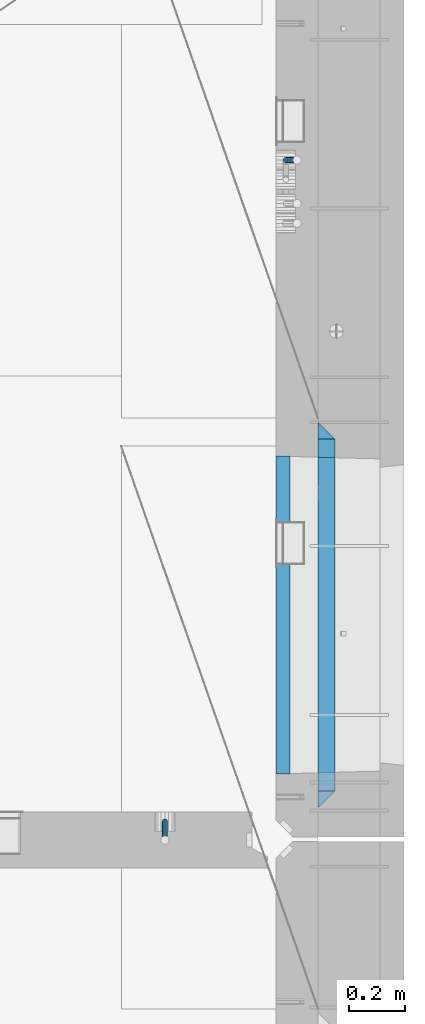
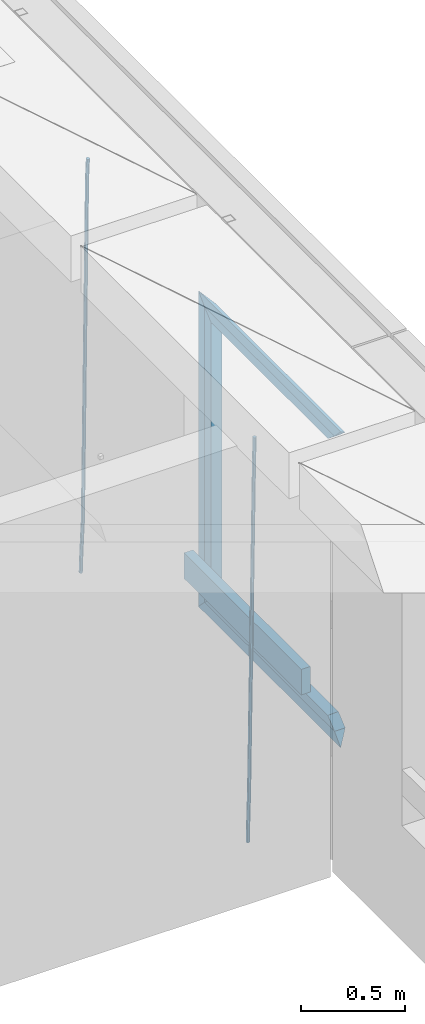
# One storey, part 128 of 341: 9 beams, 2 elements without a shape of their own.
"""IFC2X3 building model written with IfcOpenShell, lengths in millimetres."""

import ifcopenshell
import ifcopenshell.guid

model = None  # the IFC model being written
_history = None  # IfcOwnerHistory: only IFC2X3 demands one
_inside = {}  # id of a spatial element -> (the spatial element, [elements in it])
_under = {}  # id of a project, library or spatial element -> (it, [spatial elements below it])
_declared = {}  # id of a project -> (the project, [libraries it declares])
_typed = {}  # id of a type object -> (the type object, [elements of that type])
_made_of = {}  # id of a material, layer set ... -> (it, [elements and type objects made of it])


def new_model(schema):
    """Start an empty IFC model of exactly this schema.

    Asked for "IFC4X3", IfcOpenShell would pick the latest addendum, in which some entities
    have other attributes; the version numbers below select the first issue.
    IFC2X3 requires an IfcOwnerHistory on every rooted entity: one is made here for all.
    """
    global model, _history
    if schema == "IFC4X3":
        model = ifcopenshell.file(schema_version=(4, 3, 0, 0))
    else:
        model = ifcopenshell.file(schema=schema)
    _inside.clear()
    _under.clear()
    _declared.clear()
    _typed.clear()
    _made_of.clear()
    _history = None
    if model.schema == "IFC2X3":
        org = make("IfcOrganization", Name="unknown")
        user = make(
            "IfcPersonAndOrganization",
            ThePerson=make("IfcPerson", FamilyName="unknown"),
            TheOrganization=org,
        )
        app = make(
            "IfcApplication",
            ApplicationDeveloper=org,
            Version="unknown",
            ApplicationFullName="unknown",
            ApplicationIdentifier="unknown",
        )
        _history = make(
            "IfcOwnerHistory",
            OwningUser=user,
            OwningApplication=app,
            ChangeAction="ADDED",
            CreationDate=0,
        )
    return model


def make(cls, **values):
    """One entity of the class cls with the attributes given. An attribute that is None is left unset."""
    return model.create_entity(
        cls, **{name: value for name, value in values.items() if value is not None}
    )


def rooted(cls, **values):
    """An entity with a GlobalId (a new one), such as an element, a storey or a relation."""
    return make(cls, GlobalId=ifcopenshell.guid.new(), OwnerHistory=_history, **values)


def si_unit(unit_type, name, prefix=None):
    """IfcSIUnit, for example si_unit("LENGTHUNIT", "METRE", prefix="MILLI")."""
    return make("IfcSIUnit", UnitType=unit_type, Prefix=prefix, Name=name)


def assignment(units):
    """IfcUnitAssignment: the units of a project."""
    return None if units is None else make("IfcUnitAssignment", Units=units)


def point(xyz):
    """IfcCartesianPoint."""
    return None if xyz is None else make("IfcCartesianPoint", Coordinates=xyz)


def direction(xyz):
    """IfcDirection."""
    return None if xyz is None else make("IfcDirection", DirectionRatios=xyz)


def frame(location, z_axis=None, x_axis=None):
    """IfcAxis2Placement3D, a coordinate frame: its origin and axes. An axis left out is left unset."""
    return make(
        "IfcAxis2Placement3D",
        Location=point(location),
        Axis=direction(z_axis),
        RefDirection=direction(x_axis),
    )


def origin_with_axes():
    """The frame at (0, 0, 0) with the z axis (0, 0, 1) and the x axis (1, 0, 0) written out."""
    return frame((0.0, 0.0, 0.0), z_axis=(0.0, 0.0, 1.0), x_axis=(1.0, 0.0, 0.0))


def place(relative_to, where):
    """IfcLocalPlacement: puts the frame where relative to a parent placement (None: the world)."""
    return make(
        "IfcLocalPlacement", PlacementRelTo=relative_to, RelativePlacement=where
    )


def context(
    kind, dimensions, precision=None, world=None, true_north=None, identifier=None
):
    """IfcGeometricRepresentationContext, for example the 3D "Model" context."""
    return make(
        "IfcGeometricRepresentationContext",
        ContextIdentifier=identifier,
        ContextType=kind,
        CoordinateSpaceDimension=dimensions,
        Precision=precision,
        WorldCoordinateSystem=world,
        TrueNorth=true_north,
    )


def subcontext(parent, identifier, kind, view, scale=None):
    """IfcGeometricRepresentationSubContext, for example "Body" below "Model"."""
    return make(
        "IfcGeometricRepresentationSubContext",
        ContextIdentifier=identifier,
        ContextType=kind,
        ParentContext=parent,
        TargetScale=scale,
        TargetView=view,
    )


def project(units=None, contexts=None):
    """IfcProject with its units and contexts."""
    return rooted(
        "IfcProject",
        Name="project",
        RepresentationContexts=contexts,
        UnitsInContext=assignment(units),
    )


def spatial(cls, under=None, at=None, **own):
    """A site, building, storey or space (cls), placed at a placement, below another one or the project."""
    s = rooted(cls, ObjectPlacement=at, **own)
    if under is not None:
        _under.setdefault(under.id(), (under, []))[1].append(s)
    return s


def faces_of(points, faces, orient=None, outer=None):
    """IfcFace entities. A face is a list of loops; a loop is a list of indices into points, from 0.

    orient and outer hold one flag for each loop. By default every Orientation is true, the
    first loop of a face is its IfcFaceOuterBound and the others are IfcFaceBound.
    """
    made = []
    for i, loops in enumerate(faces):
        bounds = []
        for j, loop in enumerate(loops):
            is_outer = j == 0 if outer is None else outer[i][j]
            bounds.append(
                make(
                    "IfcFaceOuterBound" if is_outer else "IfcFaceBound",
                    Bound=make("IfcPolyLoop", Polygon=[points[k] for k in loop]),
                    Orientation=True if orient is None else orient[i][j],
                )
            )
        made.append(make("IfcFace", Bounds=bounds))
    return made


def faceted_brep(points, faces, orient=None, outer=None, voids=None):
    """IfcFacetedBrep: a solid bounded by flat faces; with voids (closed shells), ...WithVoids."""
    shared = [point(p) for p in points]
    hull = make("IfcClosedShell", CfsFaces=faces_of(shared, faces, orient, outer))
    if voids is None:
        return make("IfcFacetedBrep", Outer=hull)
    return make(
        "IfcFacetedBrepWithVoids",
        Outer=hull,
        Voids=[
            make(cls, CfsFaces=faces_of(shared, fs, o, b)) for cls, fs, o, b in voids
        ],
    )


def shape(context_of_items, identifier, shape_type, items):
    """IfcShapeRepresentation: the items that make up one representation, for example the "Body"."""
    return make(
        "IfcShapeRepresentation",
        ContextOfItems=context_of_items,
        RepresentationIdentifier=identifier,
        RepresentationType=shape_type,
        Items=items,
    )


def material(Name=None, Category=None):
    """IfcMaterial."""
    return make("IfcMaterial", Name=Name, Category=Category)


def made_of(thing, what):
    """Note that an element or type object is made of a material, layer set ...; save() writes the relation."""
    if what is not None:
        _made_of.setdefault(what.id(), (what, []))[1].append(thing)
    return thing


def type_object(cls, material=None, **own):
    """A type object (cls), such as IfcWallType, which elements share."""
    return made_of(rooted(cls, **own), material)


def element(
    cls,
    number,
    at=None,
    inside=None,
    cuts=None,
    type_object=None,
    material=None,
    context=None,
    identifier="Body",
    shape_type=None,
    held_by="IfcProductDefinitionShape",
    body=None,
    shapes=None,
    **own,
):
    """One element of the class cls, such as IfcWall. Its Tag is "e" and its number.

    at: its placement. inside: the storey or other place that contains it. cuts: it is an
    opening in that element (IfcRelVoidsElement). A single representation is given by context,
    identifier, shape_type and body (its items); several are given by shapes. held_by: the class
    of the entity that holds the representations. save() writes the other relations.
    """
    e = rooted(cls, Tag="e%d" % number, ObjectPlacement=at, **own)
    if body is not None:
        shapes = [shape(context, identifier, shape_type, body)]
    if shapes is not None:
        e.Representation = make(held_by, Representations=shapes)
    if inside is not None:
        _inside.setdefault(inside.id(), (inside, []))[1].append(e)
    if cuts is not None:
        rooted(
            "IfcRelVoidsElement", RelatingBuildingElement=cuts, RelatedOpeningElement=e
        )
    if type_object is not None:
        _typed.setdefault(type_object.id(), (type_object, []))[1].append(e)
    return made_of(e, material)


def aggregate(whole, parts):
    """IfcRelAggregates: a whole, such as a stair, and the parts it consists of."""
    return rooted("IfcRelAggregates", RelatingObject=whole, RelatedObjects=parts)


def save(model, path):
    """Write the relations noted so far, then the file.

    IfcRelAggregates (storeys below a building ...), IfcRelContainedInSpatialStructure (elements
    in a storey), IfcRelDefinesByType, IfcRelAssociatesMaterial and IfcRelDeclares: one each for
    every whole, place, type object, material and project.
    """
    for whole, parts in _under.values():
        aggregate(whole, parts)
    for where, things in _inside.values():
        rooted(
            "IfcRelContainedInSpatialStructure",
            RelatedElements=things,
            RelatingStructure=where,
        )
    for kind, things in _typed.values():
        rooted("IfcRelDefinesByType", RelatedObjects=things, RelatingType=kind)
    for what, things in _made_of.values():
        rooted("IfcRelAssociatesMaterial", RelatedObjects=things, RelatingMaterial=what)
    for by, libraries in _declared.values():
        rooted("IfcRelDeclares", RelatingContext=by, RelatedDefinitions=libraries)
    model.write(path)


model = new_model("IFC2X3")

# Units and contexts
model_context = context("Model", 3, precision=1e-05, world=origin_with_axes())
body_context = subcontext(model_context, "Body", "Model", "MODEL_VIEW")
ifc_project = project(units=[si_unit("LENGTHUNIT", "METRE", prefix="MILLI"), si_unit("AREAUNIT", "SQUARE_METRE"), si_unit("VOLUMEUNIT", "CUBIC_METRE"), si_unit("MASSUNIT", "GRAM", prefix="KILO"), si_unit("TIMEUNIT", "SECOND"), si_unit("PLANEANGLEUNIT", "RADIAN"), si_unit("SOLIDANGLEUNIT", "STERADIAN"), si_unit("THERMODYNAMICTEMPERATUREUNIT", "DEGREE_CELSIUS"), si_unit("LUMINOUSINTENSITYUNIT", "LUMEN")], contexts=[model_context])

# Site, building, storey
site_placement = place(None, origin_with_axes())
site = spatial("IfcSite", under=ifc_project, at=site_placement, CompositionType="ELEMENT")
building_placement = place(site_placement, origin_with_axes())
building = spatial("IfcBuilding", under=site, at=building_placement, CompositionType="ELEMENT")
storey_placement = place(building_placement, origin_with_axes())
storey = spatial("IfcBuildingStorey", under=building, at=storey_placement, Name="5", CompositionType="ELEMENT", Elevation=0.0)

# Assembly, beam
assembly_1_placement = place(storey_placement, origin_with_axes())
assembly_1 = element("IfcElementAssembly", 1, at=assembly_1_placement, inside=storey, AssemblyPlace="NOTDEFINED", PredefinedType="REINFORCEMENT_UNIT")
ifc_material_1 = material()
beam_type_1 = type_object("IfcBeamType", Name="D20", PredefinedType="NOTDEFINED")
beam_1_placement = place(assembly_1_placement, frame((34514.9999999961, 17044.9997581385, 93990.0), z_axis=(0.00020576299992186, -0.999642804629538, -0.0267249099901004), x_axis=(-4.30000201928125e-08, -0.0267249099948059, 0.999642825806181)))
beam_1 = element("IfcBeam", 2, at=beam_1_placement, type_object=beam_type_1, material=ifc_material_1, Name="JM20", ObjectType="D20", context=body_context, shape_type="Brep", body=[
    faceted_brep([(0.0, -10.0, 0.0), (-4.19531716033816e-08, -7.07106781186667, -7.07106781187031), (60.4266690400545, -7.0710677960451, -7.07106780570757), (60.4266690441291, -9.99999998418934, 6.15546014159918e-09), (0.0, 0.0, -10.0), (60.426669036824, 1.58106558956206e-08, -9.99999999384454), (4.196772351861e-08, 7.07106781186303, -7.07106781186667), (60.4266690363438, 7.07106782768096, -7.07106780570757), (0.0, 10.0, 0.0), (60.4266690388904, 10.0000000158179, 6.15182216279209e-09), (4.196772351861e-08, 7.07106781185939, 7.07106781185939), (60.4266690429649, 7.07106782768096, 7.07106781802577), (0.0, 0.0, 10.0), (60.4266690461809, 1.58179318532348e-08, 10.0000000061555), (-4.19531716033816e-08, -7.07106781187031, 7.07106781185939), (60.4266690466611, -7.07106779605238, 7.07106781802213), (61.0378400410118, -7.07106779588503, -7.07106780564936), (60.991799419251, -9.99999998403655, 6.21366780251265e-09), (61.0569027789461, 1.5985278878361e-08, -9.99999999378269), (61.0378209396877, 7.07106782784831, -7.07106780564936), (60.9917724058905, 10.0000000159635, 6.21366780251265e-09), (60.9457317841297, 7.07106782781193, 7.0710678180767), (60.9266690461809, 1.59488990902901e-08, 10.0000000062028), (60.9457508854539, -7.07106779591413, 7.0710678180767), (61.6489592143771, -7.07106614513759, -7.06310863441468), (61.5568818710308, -9.9999984576425, 0.00735959856683621), (61.6870830769039, 1.71821739058942e-06, -9.99179257185824), (61.6489210170112, 7.07106947854481, -7.06310888312146), (61.556827851804, 10.0000015422847, 0.00735924683976918), (61.4647505084577, 7.07106922979438, 7.07782747982128), (61.4266266459163, 1.36643211590126e-06, 10.0065114172685), (61.464788705809, -7.07106639389531, 7.07782772852806), (176.543135720174, -7.07075579406956, -5.56673531796696), (176.451058376813, -9.99968810657447, 1.50373291501455), (176.581259582701, 0.000312069292704109, -8.49541925541052), (176.543097522794, 7.07137982961285, -5.56673556667374), (176.451004357587, 10.00031189336, 1.50373256329476), (176.35892701424, 7.07137958085514, 8.57420079627263), (176.320803151699, 0.000311717507429421, 11.5028847337162), (176.358965211621, -7.07075604281999, 8.57420104497578), (177.098753836006, -7.07075429323595, -5.55949898843028), (176.98362511232, -9.99968666800123, 1.510669025065), (177.146421932586, 0.000313595905026887, -8.48805862247536), (177.098706077581, 7.07138133041735, -5.55949936166144), (176.983557571715, 10.0003133318824, 1.51066849724157), (176.868428848029, 7.07138095712435, 8.58083651073321), (176.820760751449, 0.000313067976094317, 11.5093961447819), (176.868476606425, -7.07075466652896, 8.58083688396073), (177.654312950661, -7.07075204110879, -5.54863964998367), (177.516135294456, -9.99968450931192, 1.52107783331303), (177.711524267797, 0.000315886711177882, -8.47701274570863), (177.654255632195, 7.07138358250813, -5.54864021007961), (177.516054233929, 10.0003154905207, 1.5210770412159), (177.377876577739, 7.0713830223176, 8.59079452451624), (177.320665260588, 0.000315094497636892, 11.5191676202448), (177.377933896176, -7.07075260129932, 8.59079508461218), (299.499456785634, -7.07025810522464, -3.16697112782276), (299.361279129444, -9.99919057342777, 3.90274635547394), (299.556668102785, 0.000809822595329024, -6.09534422354773), (299.499399467197, 7.07187751838501, -3.1669716879187), (299.361198068917, 10.0008094264049, 3.90274556338045), (299.223020412712, 7.07187695819448, 10.9724630466735), (299.165809095575, 0.000809030381788034, 13.9008361423985), (299.223077731163, -7.07025866542244, 10.9724636067695), (300.03174732349, -7.07025594743027, -3.15656661289177), (299.971788958996, -9.99918809853989, 3.91467979818117), (300.056572611924, 0.000811849109595641, -6.08557274808481), (300.031722507032, 7.07187967631762, -3.15656653768019), (299.971753863239, 10.0008119014747, 3.91467990454839), (299.91179549876, 7.07187975035777, 10.9859263156177), (299.886970210311, 0.000811953817901667, 13.9149324508144), (299.911820315203, -7.0702558733974, 10.9859262404061), (300.564137759997, -7.07025623699155, -3.15794273276697), (300.582413367199, -9.99918843065097, 3.91310145956595), (300.556570941641, 0.000811577163403854, -6.0868651410201), (300.564145451674, 7.07187938674906, -3.15794274158179), (300.582424244858, 10.0008115693345, 3.91310144710224), (300.600699852032, 7.07187937566778, 10.9841456394352), (300.608266670402, 0.000811561512819026, 13.9130680476919), (300.600692160384, -7.07025624805829, 10.98414564825), (2294.16589219622, -7.0713405251372, -8.31099358700158), (2294.1841678034, -10.0002727187966, -1.23994939466866), (2294.15832537785, -0.000272710982244462, -11.2399159952547), (2294.16589988787, 7.07079509858886, -8.31099359582004), (2294.18417868105, 9.99972728118883, -1.23994940713601), (2294.20245428824, 7.07079508752213, 5.83109478519327), (2294.2100211066, -0.00027272663282929, 8.76001719345368), (2294.20244659658, -7.07134053620393, 5.83109479401173), (2294.7782683276, -7.07134085819416, -8.31257645345977), (2294.72126025338, -10.000273010919, -1.24133766827799), (2294.84007459224, -0.000273081772320438, -11.2416781768807), (2294.87047377572, 7.07079471537872, -8.31281477453012), (2294.85165844864, 9.9997269181622, -1.24167470516841), (2294.7946503744, 7.07079476544459, 5.82956408001337), (2294.73284410976, -0.000273010977252852, 8.75866580342336), (2294.7024449263, -7.07134080815013, 5.82980240107645), (2295.39054023061, -7.0793250091956, -8.30442771922026), (2295.25826128852, -10.0072756143927, -1.23419071494573), (2295.52170777075, -0.00916171800054144, -11.2326063125765), (2295.57492774284, 7.06160849139269, -8.30343918807193), (2295.51902460904, 9.99102432676591, -1.23279272078435), (2295.38674566693, 7.06307372157607, 5.83744428349019), (2295.25557812679, -0.0070895696117077, 8.76562287684646), (2295.20235815471, -7.07785977901949, 5.83645575234186), (2317.1947101649, -7.36365585014573, -8.01423575520312), (2317.06243122277, -10.2916064553428, -0.94399875092131), (2317.32587770502, -0.293492558957951, -10.9424143485521), (2317.37909767711, 6.77727765044983, -8.01324722405116), (2317.32319454331, 9.70669348581578, -0.942600756767206), (2317.1909156012, 6.77874288063322, 6.12763624751096), (2317.05974806109, -0.291420410569117, 9.0558148408636), (2317.00652808898, -7.36219061996962, 6.12664771636264), (2317.83015404257, -7.37194216843636, -8.00577862486898), (2317.72252095213, -10.300214160583, -0.935213608652703), (2317.90419832576, -0.301033978277701, -10.9347174723516), (2317.90127966482, 6.77046829039318, -8.00629749759901), (2317.82310777172, 9.70017451494641, -0.935947405505431), (2317.71547468127, 6.77190252279979, 6.13461761071085), (2317.64143039809, -0.29900566735887, 9.06355645819713), (2317.64434905903, -7.37050793602975, 6.13513648344451), (2318.46565174212, -7.3700661537805, -7.99751648408346), (2318.38266643914, -10.2982456018653, -0.926623872735945), (2318.48256818345, -0.299336209594912, -10.9272153854981), (2318.42350634121, 6.77200652527245, -7.99954269419686), (2318.32306384158, 9.70166538090416, -0.929489366557391), (2318.2400785386, 6.77348593281204, 6.14140324480104), (2318.22316209726, -0.297244011366274, 9.07110214621207), (2318.2822239395, -7.36858674623363, 6.1434294549108), (2418.48643733139, -7.07180401323421, -6.70013846199799), (2418.4034520284, -9.99998346132634, 0.370754149349523), (2418.5033537727, -0.00107406904135132, -9.62983736341266), (2418.44429193046, 7.07026866581873, -6.70216467211139), (2418.34384943081, 9.99992752145772, 0.367888655531715), (2418.26086412782, 7.0717480733656, 7.43878126688651), (2418.24394768651, 0.00101812917273492, 10.3684801682975), (2418.30300952874, -7.07032460568735, 7.44080747699627)], [[[0, 1, 2, 3]], [[1, 4, 5, 2]], [[4, 6, 7, 5]], [[6, 8, 9, 7]], [[8, 10, 11, 9]], [[10, 12, 13, 11]], [[12, 14, 15, 13]], [[14, 0, 3, 15]], [[14, 12, 10, 8, 6, 4, 1, 0]], [[3, 2, 16, 17]], [[2, 5, 18, 16]], [[5, 7, 19, 18]], [[7, 9, 20, 19]], [[9, 11, 21, 20]], [[11, 13, 22, 21]], [[13, 15, 23, 22]], [[15, 3, 17, 23]], [[17, 16, 24, 25]], [[16, 18, 26, 24]], [[18, 19, 27, 26]], [[19, 20, 28, 27]], [[20, 21, 29, 28]], [[21, 22, 30, 29]], [[22, 23, 31, 30]], [[23, 17, 25, 31]], [[25, 24, 32, 33]], [[24, 26, 34, 32]], [[26, 27, 35, 34]], [[27, 28, 36, 35]], [[28, 29, 37, 36]], [[29, 30, 38, 37]], [[30, 31, 39, 38]], [[31, 25, 33, 39]], [[33, 32, 40, 41]], [[32, 34, 42, 40]], [[34, 35, 43, 42]], [[35, 36, 44, 43]], [[36, 37, 45, 44]], [[37, 38, 46, 45]], [[38, 39, 47, 46]], [[39, 33, 41, 47]], [[41, 40, 48, 49]], [[40, 42, 50, 48]], [[42, 43, 51, 50]], [[43, 44, 52, 51]], [[44, 45, 53, 52]], [[45, 46, 54, 53]], [[46, 47, 55, 54]], [[47, 41, 49, 55]], [[49, 48, 56, 57]], [[48, 50, 58, 56]], [[50, 51, 59, 58]], [[51, 52, 60, 59]], [[52, 53, 61, 60]], [[53, 54, 62, 61]], [[54, 55, 63, 62]], [[55, 49, 57, 63]], [[57, 56, 64, 65]], [[56, 58, 66, 64]], [[58, 59, 67, 66]], [[59, 60, 68, 67]], [[60, 61, 69, 68]], [[61, 62, 70, 69]], [[62, 63, 71, 70]], [[63, 57, 65, 71]], [[65, 64, 72, 73]], [[64, 66, 74, 72]], [[66, 67, 75, 74]], [[67, 68, 76, 75]], [[68, 69, 77, 76]], [[69, 70, 78, 77]], [[70, 71, 79, 78]], [[71, 65, 73, 79]], [[73, 72, 80, 81]], [[72, 74, 82, 80]], [[74, 75, 83, 82]], [[75, 76, 84, 83]], [[76, 77, 85, 84]], [[77, 78, 86, 85]], [[78, 79, 87, 86]], [[79, 73, 81, 87]], [[81, 80, 88, 89]], [[80, 82, 90, 88]], [[82, 83, 91, 90]], [[83, 84, 92, 91]], [[84, 85, 93, 92]], [[85, 86, 94, 93]], [[86, 87, 95, 94]], [[87, 81, 89, 95]], [[89, 88, 96, 97]], [[88, 90, 98, 96]], [[90, 91, 99, 98]], [[91, 92, 100, 99]], [[92, 93, 101, 100]], [[93, 94, 102, 101]], [[94, 95, 103, 102]], [[95, 89, 97, 103]], [[97, 96, 104, 105]], [[96, 98, 106, 104]], [[98, 99, 107, 106]], [[99, 100, 108, 107]], [[100, 101, 109, 108]], [[101, 102, 110, 109]], [[102, 103, 111, 110]], [[103, 97, 105, 111]], [[105, 104, 112, 113]], [[104, 106, 114, 112]], [[106, 107, 115, 114]], [[107, 108, 116, 115]], [[108, 109, 117, 116]], [[109, 110, 118, 117]], [[110, 111, 119, 118]], [[111, 105, 113, 119]], [[113, 112, 120, 121]], [[112, 114, 122, 120]], [[114, 115, 123, 122]], [[115, 116, 124, 123]], [[116, 117, 125, 124]], [[117, 118, 126, 125]], [[118, 119, 127, 126]], [[119, 113, 121, 127]], [[121, 120, 128, 129]], [[120, 122, 130, 128]], [[122, 123, 131, 130]], [[123, 124, 132, 131]], [[124, 125, 133, 132]], [[125, 126, 134, 133]], [[126, 127, 135, 134]], [[127, 121, 129, 135]], [[130, 131, 132, 133, 134, 135, 129, 128]]]),
])
aggregate(assembly_1, [beam_1])

# Assembly, beams
assembly_2_placement = place(storey_placement, origin_with_axes())
assembly_2 = element("IfcElementAssembly", 3, at=assembly_2_placement, inside=storey, AssemblyPlace="NOTDEFINED", PredefinedType="REINFORCEMENT_UNIT")
beam_2_placement = place(assembly_2_placement, frame((34944.9999977209, 19397.5002651175, 93995.0), z_axis=(0.999642804629538, 0.000205762999925497, -0.0267249099901003), x_axis=(0.0267249109941254, -4.30000210532798e-08, 0.999642825779465)))
beam_2 = element("IfcBeam", 4, at=beam_2_placement, type_object=beam_type_1, material=ifc_material_1, Name="JM20", ObjectType="D20", context=body_context, shape_type="Brep", body=[
    faceted_brep([(0.0, -10.0, 0.0), (-4.19531716033816e-08, -7.07106781186667, -7.07106781187031), (60.4266690400545, -7.0710677960451, -7.07106780570757), (60.4266690441291, -9.99999998418934, 6.15546014159918e-09), (0.0, 0.0, -10.0), (60.426669036824, 1.58106558956206e-08, -9.99999999384454), (4.196772351861e-08, 7.07106781186303, -7.07106781186667), (60.4266690363438, 7.07106782768096, -7.07106780570757), (0.0, 10.0, 0.0), (60.4266690388904, 10.0000000158179, 6.15182216279209e-09), (4.196772351861e-08, 7.07106781185939, 7.07106781185939), (60.4266690429649, 7.07106782768096, 7.07106781802577), (0.0, 0.0, 10.0), (60.4266690461809, 1.58179318532348e-08, 10.0000000061555), (-4.19531716033816e-08, -7.07106781187031, 7.07106781185939), (60.4266690466611, -7.07106779605238, 7.07106781802213), (61.0378400410118, -7.07106779588503, -7.07106780564936), (60.991799419251, -9.99999998403655, 6.21366780251265e-09), (61.0569027789461, 1.5985278878361e-08, -9.99999999378269), (61.0378209396877, 7.07106782784831, -7.07106780564936), (60.9917724058905, 10.0000000159635, 6.21366780251265e-09), (60.9457317841297, 7.07106782781193, 7.0710678180767), (60.9266690461809, 1.59488990902901e-08, 10.0000000062028), (60.9457508854539, -7.07106779591413, 7.0710678180767), (61.6489592143771, -7.07106614513759, -7.06310863441468), (61.5568818710308, -9.9999984576425, 0.00735959856683621), (61.6870830769039, 1.71821739058942e-06, -9.99179257185824), (61.6489210170112, 7.07106947854481, -7.06310888312146), (61.556827851804, 10.0000015422847, 0.00735924683976918), (61.4647505084577, 7.07106922979438, 7.07782747982128), (61.4266266459163, 1.36643211590126e-06, 10.0065114172685), (61.464788705809, -7.07106639389531, 7.07782772852806), (176.543135720174, -7.07075579406956, -5.56673531796696), (176.451058376813, -9.99968810657447, 1.50373291501455), (176.581259582701, 0.000312069292704109, -8.49541925541052), (176.543097522794, 7.07137982961285, -5.56673556667374), (176.451004357587, 10.00031189336, 1.50373256329476), (176.35892701424, 7.07137958085514, 8.57420079627263), (176.320803151699, 0.000311717507429421, 11.5028847337162), (176.358965211621, -7.07075604281999, 8.57420104497578), (177.098753836006, -7.07075429323595, -5.55949898843028), (176.98362511232, -9.99968666800123, 1.510669025065), (177.146421932586, 0.000313595905026887, -8.48805862247536), (177.098706077581, 7.07138133041735, -5.55949936166144), (176.983557571715, 10.0003133318824, 1.51066849724157), (176.868428848029, 7.07138095712435, 8.58083651073321), (176.820760751449, 0.000313067976094317, 11.5093961447819), (176.868476606425, -7.07075466652896, 8.58083688396073), (177.654312950661, -7.07075204110879, -5.54863964998367), (177.516135294456, -9.99968450931192, 1.52107783331303), (177.711524267797, 0.000315886711177882, -8.47701274570863), (177.654255632195, 7.07138358250813, -5.54864021007961), (177.516054233929, 10.0003154905207, 1.5210770412159), (177.377876577739, 7.0713830223176, 8.59079452451624), (177.320665260588, 0.000315094497636892, 11.5191676202448), (177.377933896176, -7.07075260129932, 8.59079508461218), (299.436796249574, -7.07025836271714, -3.1681962331204), (299.298618593355, -9.99919083092027, 3.90152125031091), (299.494007566798, 0.000809565110102994, -6.09656932889993), (299.436738931283, 7.07187726089978, -3.16819679320906), (299.298537533061, 10.0008091689197, 3.90152045822106), (299.160359876842, 7.07187670072017, 10.9712379416487), (299.103148559603, 0.000808772889286047, 13.8996110374392), (299.160417195119, -7.07025892290039, 10.9712385017483), (299.98743051647, -7.07025613056248, -3.15743315966392), (299.971788958996, -9.99918809853989, 3.91467979818117), (299.993912075952, 0.000811591617093654, -6.08679785393178), (299.987423933868, 7.07187949325817, -3.1574327280432), (299.971753863239, 10.0008119014747, 3.91467990454839), (299.95611230444, 7.07187992653053, 10.9867922621015), (299.949630744944, 0.000812204350950196, 13.9161569563694), (299.956118887014, -7.07025569729012, 10.9867918304735), (300.538107039494, -7.07025785017686, -3.16575821840888), (300.644985195438, -9.99919020432935, 3.90450175465594), (300.493854948218, 0.000810030429420294, -6.09435592770024), (300.538151196495, 7.071877773491, -3.16575855385963), (300.645047642858, 10.0008097955724, 3.90450128024895), (300.751925798773, 7.07187744142357, 10.9747612533101), (300.796177890064, 0.000809560813650023, 13.9033589625978), (300.751881641787, -7.07025818224065, 10.9747615887682), (2293.36490490142, -7.07648090940347, -33.2930642912361), (2293.47178305736, -10.0054132635523, -26.2228043181785), (2293.32065281013, -0.00541302880083094, -36.2216620005347), (2293.36494905842, 7.06565471425711, -33.2930646266868), (2293.47184550477, 9.99458673634581, -26.2228047925819), (2293.57872366071, 7.06565438219332, -19.1525448195243), (2293.62297575199, -0.00541349841296324, -16.2239471102366), (2293.57867950371, -7.0764812414709, -19.1525444840736), (2294.0658245362, -7.07648309818615, -33.3036607065333), (2294.05312277409, -10.0054150789219, -26.2315929392535), (2294.10928714235, -0.00541549149056664, -36.2335844756526), (2294.15805078732, 7.06565223761572, -33.3050546393533), (2294.18355038921, 9.99458451388637, -26.2335642579346), (2294.17084862708, 7.06565253314329, -19.1614964906439), (2294.12738602093, -0.00541507354500936, -16.2315727215355), (2294.07862237596, -7.07648280265857, -19.1601025578348), (2294.76670261032, -7.08562269121467, -33.294332712383), (2294.63442802057, -10.0129954178956, -26.2238563411993), (2294.89787471293, -0.0156988342423574, -36.2230891548279), (2294.95110548967, 7.05531064255774, -33.2944998654275), (2294.89521307347, 9.98530428734011, -26.2240927312887), (2294.76293848372, 7.0579315606592, -19.1536163601049), (2294.63176638114, -0.0119922963167483, -16.2248599176673), (2294.57853560438, -7.08300177311321, -19.1534492070678), (2316.52657204497, -7.36937582653991, -33.0047303660212), (2316.39429745522, -10.2967485532172, -25.9342539948302), (2316.65774414754, -0.299451969567599, -35.9334868084661), (2316.7109749243, 6.7715575072325, -33.0048975190657), (2316.65508250811, 9.70155115201487, -25.9344903849269), (2316.52280791836, 6.7741784253376, -18.8640140137468), (2316.39163581574, -0.295745431634714, -15.9352575713092), (2316.33840503903, -7.36675490843481, -18.863846860706), (2317.16202064224, -7.37766220584308, -32.9962731735213), (2317.05438744847, -10.3053562613532, -25.9254688497131), (2317.23607125619, -0.306993473008333, -35.925789846493), (2317.23316144495, 6.76474808850253, -32.9979477328052), (2317.15499573652, 9.6950321815566, -25.9278370341635), (2317.04736254275, 6.7673381260538, -18.8570327103698), (2316.97331192881, -0.303330606784584, -15.9275160373909), (2316.97622174003, -7.37507216829545, -18.8553581510787), (2317.79752306276, -7.37578610372293, -32.9880110666527), (2317.71453320107, -10.3033876998124, -25.9168792378296), (2317.81444760226, -0.305295583297266, -35.918287695793), (2317.75539265381, 6.76628640723357, -32.9911928173897), (2317.65495180529, 9.69652304524061, -25.9213789128698), (2317.5719619436, 6.76892144914746, -18.8502470840467), (2317.55503740412, -0.301569071270933, -15.9199704549137), (2317.61409235255, -7.3731510618054, -18.847065333317), (2417.8183084176, -7.07752398473531, -31.6906369377139), (2417.73531855589, -10.0051255808248, -24.6195051088798), (2417.83523295709, -0.007033464313281, -34.6209135668432), (2417.77617800863, 7.06454852621755, -31.6938186884508), (2417.67573716014, 9.99478516423187, -24.6240047839383), (2417.59274729842, 7.06718356813872, -17.5528729551006), (2417.57582275895, -0.00330695228694822, -14.6225963259749), (2417.6348777074, -7.07488894281778, -17.5496912043673)], [[[0, 1, 2, 3]], [[1, 4, 5, 2]], [[4, 6, 7, 5]], [[6, 8, 9, 7]], [[8, 10, 11, 9]], [[10, 12, 13, 11]], [[12, 14, 15, 13]], [[14, 0, 3, 15]], [[14, 12, 10, 8, 6, 4, 1, 0]], [[3, 2, 16, 17]], [[2, 5, 18, 16]], [[5, 7, 19, 18]], [[7, 9, 20, 19]], [[9, 11, 21, 20]], [[11, 13, 22, 21]], [[13, 15, 23, 22]], [[15, 3, 17, 23]], [[17, 16, 24, 25]], [[16, 18, 26, 24]], [[18, 19, 27, 26]], [[19, 20, 28, 27]], [[20, 21, 29, 28]], [[21, 22, 30, 29]], [[22, 23, 31, 30]], [[23, 17, 25, 31]], [[25, 24, 32, 33]], [[24, 26, 34, 32]], [[26, 27, 35, 34]], [[27, 28, 36, 35]], [[28, 29, 37, 36]], [[29, 30, 38, 37]], [[30, 31, 39, 38]], [[31, 25, 33, 39]], [[33, 32, 40, 41]], [[32, 34, 42, 40]], [[34, 35, 43, 42]], [[35, 36, 44, 43]], [[36, 37, 45, 44]], [[37, 38, 46, 45]], [[38, 39, 47, 46]], [[39, 33, 41, 47]], [[41, 40, 48, 49]], [[40, 42, 50, 48]], [[42, 43, 51, 50]], [[43, 44, 52, 51]], [[44, 45, 53, 52]], [[45, 46, 54, 53]], [[46, 47, 55, 54]], [[47, 41, 49, 55]], [[49, 48, 56, 57]], [[48, 50, 58, 56]], [[50, 51, 59, 58]], [[51, 52, 60, 59]], [[52, 53, 61, 60]], [[53, 54, 62, 61]], [[54, 55, 63, 62]], [[55, 49, 57, 63]], [[57, 56, 64, 65]], [[56, 58, 66, 64]], [[58, 59, 67, 66]], [[59, 60, 68, 67]], [[60, 61, 69, 68]], [[61, 62, 70, 69]], [[62, 63, 71, 70]], [[63, 57, 65, 71]], [[65, 64, 72, 73]], [[64, 66, 74, 72]], [[66, 67, 75, 74]], [[67, 68, 76, 75]], [[68, 69, 77, 76]], [[69, 70, 78, 77]], [[70, 71, 79, 78]], [[71, 65, 73, 79]], [[73, 72, 80, 81]], [[72, 74, 82, 80]], [[74, 75, 83, 82]], [[75, 76, 84, 83]], [[76, 77, 85, 84]], [[77, 78, 86, 85]], [[78, 79, 87, 86]], [[79, 73, 81, 87]], [[81, 80, 88, 89]], [[80, 82, 90, 88]], [[82, 83, 91, 90]], [[83, 84, 92, 91]], [[84, 85, 93, 92]], [[85, 86, 94, 93]], [[86, 87, 95, 94]], [[87, 81, 89, 95]], [[89, 88, 96, 97]], [[88, 90, 98, 96]], [[90, 91, 99, 98]], [[91, 92, 100, 99]], [[92, 93, 101, 100]], [[93, 94, 102, 101]], [[94, 95, 103, 102]], [[95, 89, 97, 103]], [[97, 96, 104, 105]], [[96, 98, 106, 104]], [[98, 99, 107, 106]], [[99, 100, 108, 107]], [[100, 101, 109, 108]], [[101, 102, 110, 109]], [[102, 103, 111, 110]], [[103, 97, 105, 111]], [[105, 104, 112, 113]], [[104, 106, 114, 112]], [[106, 107, 115, 114]], [[107, 108, 116, 115]], [[108, 109, 117, 116]], [[109, 110, 118, 117]], [[110, 111, 119, 118]], [[111, 105, 113, 119]], [[113, 112, 120, 121]], [[112, 114, 122, 120]], [[114, 115, 123, 122]], [[115, 116, 124, 123]], [[116, 117, 125, 124]], [[117, 118, 126, 125]], [[118, 119, 127, 126]], [[119, 113, 121, 127]], [[121, 120, 128, 129]], [[120, 122, 130, 128]], [[122, 123, 131, 130]], [[123, 124, 132, 131]], [[124, 125, 133, 132]], [[125, 126, 134, 133]], [[126, 127, 135, 134]], [[127, 121, 129, 135]], [[130, 131, 132, 133, 134, 135, 129, 128]]]),
])
ifc_material_2 = material(Name="TIMBER/T24")
beam_type_2 = type_object("IfcBeamType", PredefinedType="NOTDEFINED")
beam_3_placement = place(assembly_2_placement, frame((34935.0002758707, 17215.0011464907, 94685.0), z_axis=(0.0, 0.0, 1.0), x_axis=(0.0, 1.0, 0.0)))
beam_3 = element("IfcBeam", 5, at=beam_3_placement, type_object=beam_type_2, material=ifc_material_2, context=body_context, shape_type="Brep", body=[
    faceted_brep([(-3.63797880709171e-12, 24.9999999999964, -75.0), (-3.63797880709171e-12, 24.9999999999964, 75.0), (1130.0, 25.0, 75.0), (1130.0, 25.0, -75.0), (0.0, -25.0000000000073, 75.0), (1130.0, -25.0, 75.0), (0.0, -25.0000000000073, -75.0), (1130.0, -25.0, -75.0)], [[[0, 1, 2, 3]], [[1, 4, 5, 2]], [[4, 6, 7, 5]], [[6, 0, 3, 7]], [[5, 7, 3, 2]], [[6, 4, 1, 0]]]),
])
ifc_material_3 = material(Name="CONCRETE/C25/30")
beam_type_3 = type_object("IfcBeamType", PredefinedType="NOTDEFINED")
beam_4_placement = place(assembly_2_placement, frame((35090.0, 17095.0018965848, 96145.0), z_axis=(0.0, 0.0, -1.0), x_axis=(0.0, 1.0, 0.0)))
beam_4 = element("IfcBeam", 6, at=beam_4_placement, type_object=beam_type_3, material=ifc_material_3, Name="SK", context=body_context, shape_type="Brep", body=[
    faceted_brep([(60.0000000000073, 30.0, 30.0), (0.0, -30.0, -30.0), (60.0000000000073, -30.0, 30.0), (1309.99847412109, 30.0, 30.0), (1369.99847412109, -30.0, -30.0), (1309.99847412109, -30.0, 30.0)], [[[0, 1, 2]], [[1, 0, 3, 4]], [[2, 1, 4, 5]], [[0, 2, 5, 3]], [[3, 5, 4]]]),
])
beam_5_placement = place(assembly_2_placement, frame((35090.0, 17155.0018965848, 96085.0), z_axis=(0.0, 0.0, -1.0), x_axis=(0.0, 1.0, 0.0)))
beam_5 = element("IfcBeam", 7, at=beam_5_placement, type_object=beam_type_3, material=ifc_material_3, Name="SK", context=body_context, shape_type="Brep", body=[
    faceted_brep([(1185.94442006696, -29.999999998452, 24.0540540541406), (1184.32279844542, 29.999999998452, 25.6756756756804), (65.6741497967687, 29.999999998452, 25.6756756756804), (64.0525281752307, -29.999999998452, 24.0540540541406), (65.6741497967687, 29.999999998452, 26.2921283848846), (64.0525281752307, -29.999999998452, 24.9021669953072), (0.0, 30.0, -30.0), (0.0, -30.0, -30.0), (1249.99847412109, 29.999999998452, -30.0), (1249.99847412109, -29.999999998452, -30.0), (1185.94442006696, -29.999999998452, 24.9034748915001), (1184.32279844542, 29.999999998452, 26.2934362810629)], [[[0, 1, 2, 3]], [[3, 2, 4, 5]], [[4, 6, 7, 5]], [[7, 6, 8, 9]], [[0, 3, 5, 7, 9, 10]], [[1, 0, 10, 11]], [[6, 4, 2, 1, 11, 8]], [[8, 11, 10, 9]]]),
])
beam_6_placement = place(assembly_2_placement, frame((35090.0, 18435.0003707059, 96175.0), z_axis=(0.0, -1.0, 0.0), x_axis=(0.0, 0.0, -1.0)))
beam_6 = element("IfcBeam", 8, at=beam_6_placement, type_object=beam_type_3, material=ifc_material_3, Name="SK", context=body_context, shape_type="Brep", body=[
    faceted_brep([(60.0000000000073, 30.0, 30.0), (0.0, -30.0, -30.0), (60.0000000000073, -30.0, 30.0), (1795.00000000001, 30.0, 30.0), (1855.0, -30.0, -30.0), (1795.00000000001, -30.0, 30.0)], [[[0, 1, 2]], [[3, 4, 1, 0]], [[4, 5, 2, 1]], [[5, 3, 0, 2]], [[5, 4, 3]]]),
])
beam_7_placement = place(assembly_2_placement, frame((35090.0, 18465.0003707059, 94350.0), z_axis=(0.0, 0.0, 1.0), x_axis=(0.0, -1.0, 0.0)))
beam_7 = element("IfcBeam", 9, at=beam_7_placement, type_object=beam_type_3, material=ifc_material_3, Name="SK", context=body_context, shape_type="Brep", body=[
    faceted_brep([(1309.99847412109, 30.0, 30.0), (1309.99847412109, -30.0, 30.0), (1369.99847412109, -30.0, -30.0), (60.0000000000073, 30.0, 30.0), (60.0000000000073, -30.0, 30.0), (0.0, -30.0, -30.0)], [[[0, 1, 2]], [[3, 4, 1, 0]], [[4, 5, 2, 1]], [[5, 3, 0, 2]], [[3, 5, 4]]]),
])
beam_8_placement = place(assembly_2_placement, frame((35090.0, 18405.0003707059, 94410.0), z_axis=(0.0, 0.0, 1.0), x_axis=(0.0, -1.0, 0.0)))
beam_8 = element("IfcBeam", 10, at=beam_8_placement, type_object=beam_type_3, material=ifc_material_3, Name="SK", context=body_context, shape_type="Brep", body=[
    faceted_brep([(1185.94594588314, -29.9999988381387, 24.0540541168593), (1184.32432432432, 29.9999988381387, 25.6756756756804), (65.6756756756768, 30.0, 25.6756756756804), (64.0540540540533, -30.0, 24.0540540540533), (1185.94594594586, -29.999999998452, 24.9021669952926), (1184.32432432433, 29.999999998452, 26.2921283848846), (1249.99847412109, -29.999999998452, -30.0), (1249.99847412109, 29.999999998452, -30.0), (0.0, 30.0, -30.0), (65.6756756756768, 30.0, 26.293436281092), (64.0540540540533, -30.0, 24.9034748914419), (0.0, -30.0, -30.0)], [[[0, 1, 2, 3]], [[1, 0, 4, 5]], [[5, 4, 6, 7]], [[2, 1, 5, 7, 8, 9]], [[3, 2, 9, 10]], [[6, 4, 0, 3, 10, 11]], [[11, 8, 7, 6]], [[11, 10, 9, 8]]]),
])
beam_type_4 = type_object("IfcBeamType", PredefinedType="NOTDEFINED")
beam_9_placement = place(assembly_2_placement, frame((35090.0, 18370.0003707059, 96115.0), z_axis=(0.0, -1.0, 0.0), x_axis=(0.0, 0.0, -1.0)))
beam_9 = element("IfcBeam", 11, at=beam_9_placement, type_object=beam_type_4, material=ifc_material_3, Name="SK", context=body_context, shape_type="Brep", body=[
    faceted_brep([(0.0, -30.0, -35.0), (54.9034748914273, -30.0, 29.0540540540533), (56.2934362811066, 30.0, 30.6756756756768), (0.0, 30.0, -35.0), (1735.0, 30.0, -35.0), (1735.0, -30.0, -35.0), (1680.09652510857, -30.0, 29.0540540540533), (1678.70656371891, 30.0, 30.6756756756768)], [[[0, 1, 2, 3]], [[4, 5, 0, 3]], [[1, 0, 5, 6]], [[2, 1, 6, 7]], [[3, 2, 7, 4]], [[5, 4, 7, 6]]]),
])
aggregate(assembly_2, [beam_2, beam_4, beam_5, beam_6, beam_9, beam_7, beam_8, beam_3])

save(model, "model.ifc")
